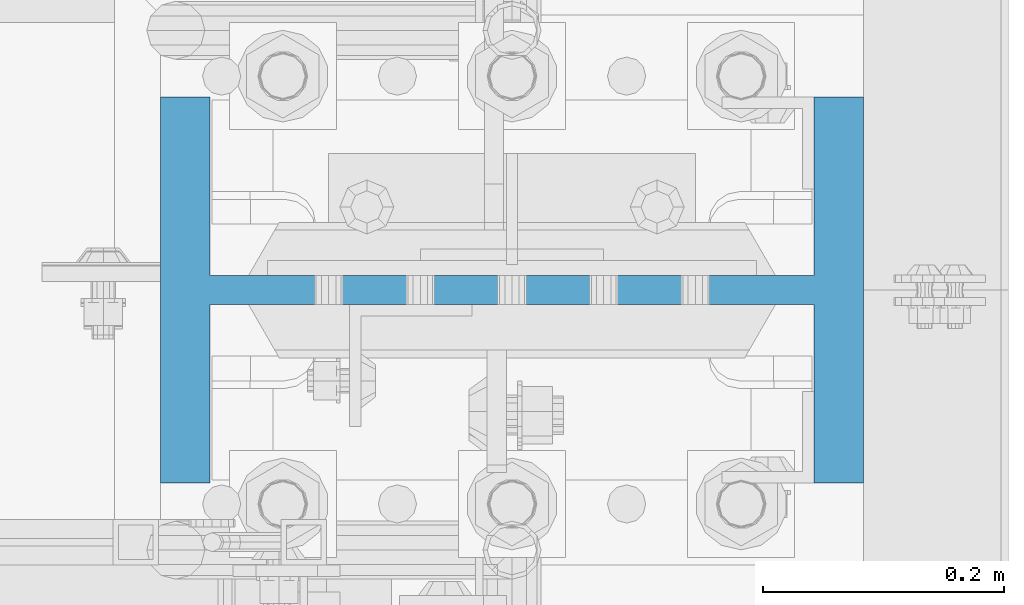
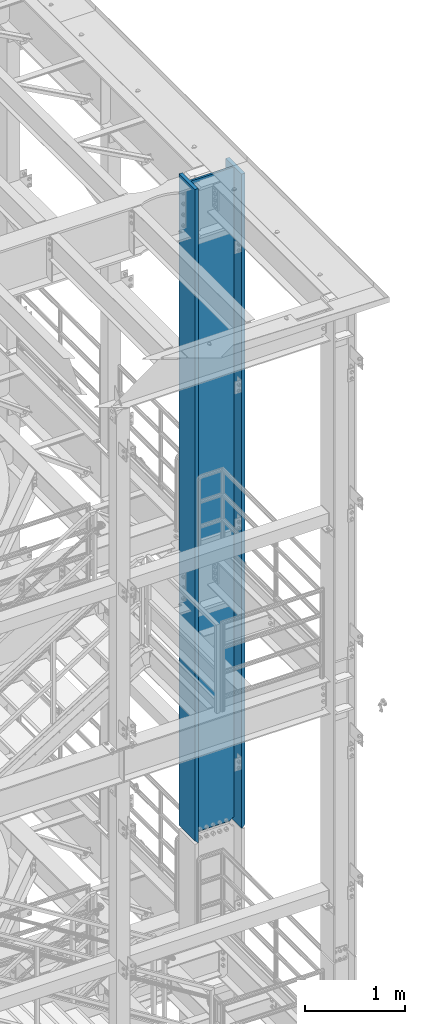
# One storey, part 666 of 1876: 1 column, 1 element without a shape of its own.
"""IFC2X3 building model written with IfcOpenShell, lengths in millimetres."""

from ifc_helpers import new_model, si_unit, frame, origin_with_axes, place, context, subcontext, project, spatial, faceted_brep, material, type_object, element, aggregate, save


model = new_model("IFC2X3")

# Units and contexts
model_context = context("Model", 3, precision=1e-05, world=origin_with_axes())
body_context = subcontext(model_context, "Body", "Model", "MODEL_VIEW")
ifc_project = project(units=[si_unit("LENGTHUNIT", "METRE", prefix="MILLI"), si_unit("AREAUNIT", "SQUARE_METRE"), si_unit("VOLUMEUNIT", "CUBIC_METRE"), si_unit("MASSUNIT", "GRAM", prefix="KILO"), si_unit("TIMEUNIT", "SECOND"), si_unit("PLANEANGLEUNIT", "RADIAN"), si_unit("SOLIDANGLEUNIT", "STERADIAN"), si_unit("THERMODYNAMICTEMPERATUREUNIT", "DEGREE_CELSIUS"), si_unit("LUMINOUSINTENSITYUNIT", "LUMEN")], contexts=[model_context])

# Site, building, storey
site_placement = place(None, origin_with_axes())
site = spatial("IfcSite", under=ifc_project, at=site_placement, CompositionType="ELEMENT")
building_placement = place(site_placement, origin_with_axes())
building = spatial("IfcBuilding", under=site, at=building_placement, Name="Undefined", CompositionType="ELEMENT")
storey_placement = place(building_placement, origin_with_axes())
storey = spatial("IfcBuildingStorey", under=building, at=storey_placement, Name="Undefined", CompositionType="ELEMENT", Elevation=0.0)

# Assembly, column
assembly_placement = place(storey_placement, origin_with_axes())
assembly = element("IfcElementAssembly", 1, at=assembly_placement, inside=storey, Name="COLUMN", AssemblyPlace="NOTDEFINED", PredefinedType="RIGID_FRAME")
ifc_material = material(Name="STEEL/A992")
column_type = type_object("IfcColumnType", Name="W21X201", PredefinedType="NOTDEFINED")
column_placement = place(assembly_placement, frame((7620.0, -4572.0, 14528.8), z_axis=(-1.0, 0.0, 0.0), x_axis=(0.0, 0.0, 1.0)))
column = element("IfcColumn", 2, at=column_placement, type_object=column_type, material=ifc_material, Name="COLUMN", ObjectType="W21X201", context=body_context, shape_type="Brep", body=[
    faceted_brep([(26.9875007629398, -11.9062500000018, 204.691852352942), (25.7903180721823, -10.7090673092443, 203.891920453292), (6.35000000000036, 8.73125076293763, 200.02500076294), (6.35000000000036, 8.73125076293763, -200.02500076294), (25.7903188351211, -10.7090680721831, -203.891920453292), (26.9875007629398, -11.90625, -204.691851843163), (42.2710247077357, -11.90625, -214.903976055204), (42.2710247077357, 11.90625, -214.903976055204), (53.2830803096476, 11.90625, -231.384681927818), (53.2830803096476, -11.90625, -231.384681927818), (8026.4, -160.3375, 292.1), (8026.4, 160.3375, 292.1), (44.4500000000007, 160.3375, 292.1), (44.4500000000007, -160.3375, 292.1), (6.35000000000036, -160.3375, 250.825), (57.1499992370609, -160.3375, 250.825), (8026.4, -160.3375, 250.825), (6.35000000000036, -160.3375, 254.0), (6.35000000000036, -11.90625, 250.825), (6.35000000000036, 160.3375, 254.0), (6.35000000000036, 160.3375, 250.825), (6.35000000000036, 11.90625, 250.825), (6.35000000000036, 8.73125076293763, 250.825), (8026.4, 160.3375, 250.825), (57.1499992370609, 160.3375, 250.825), (57.1499992370609, 11.90625, 250.825), (8026.4, 11.90625, 250.825), (57.1499992370609, -11.90625, 250.825000000001), (53.2830795467089, 11.90625, 231.384681927818), (53.2830795467089, -11.90625, 231.384681927818), (26.9875007629398, -11.90625, 250.825), (8026.4, -11.90625, 250.825), (57.1499999999996, 160.3375, -250.825), (6.35000000000036, 160.3375, -250.825), (6.35000000000036, 11.90625, -250.825), (57.1499999999996, 11.90625, -250.825), (8026.4, 11.90625, -250.825), (8026.4, 160.3375, -250.825), (8026.4, 160.3375, -292.1), (8026.4, -160.3375, -292.1), (44.4500000000007, -160.3375, -292.1), (44.4500000000007, 160.3375, -292.1), (8026.4, -160.3375, -250.825), (57.1499999999996, -160.3375, -250.825), (6.35000000000036, -160.3375, -250.825), (6.35000000000036, -160.3375, -254.000000000001), (6.35000000000036, 160.3375, -254.000000000001), (8026.4, -11.90625, -250.825), (57.1499999999996, -11.90625, -250.825000000001), (26.9875007629398, -11.90625, -250.825), (6.35000000000036, -11.90625, -250.825), (6.35000000000036, 8.73125076293763, -250.825), (25.7903188351211, 11.90625, -203.891920453292), (6.35000000000036, 11.90625, -200.02500076294), (6.35000000000036, 11.90625, 200.02500076294), (25.7903180721823, 11.90625, 203.891920453292), (42.271023944797, 11.90625, 214.903976055204), (42.271023944797, -11.90625, 214.903976055204)], [[[0, 1, 2, 3, 4, 5]], [[6, 7, 8, 9]], [[10, 11, 12, 13]], [[14, 15, 16, 10, 13, 17]], [[18, 14, 17, 19, 20, 21, 22]], [[13, 12, 19, 17]], [[11, 23, 24, 20, 19, 12]], [[25, 21, 20, 24, 23, 26]], [[27, 25, 28, 29]], [[30, 18, 22, 21, 25, 27]], [[15, 14, 18, 30, 27, 31, 16]], [[32, 33, 34, 35, 36, 37]], [[38, 39, 40, 41]], [[39, 42, 43, 44, 45, 40]], [[40, 45, 46, 41]], [[33, 32, 37, 38, 41, 46]], [[36, 26, 23, 11, 10, 16, 31, 47, 42, 39, 38, 37]], [[48, 49, 50, 44, 43, 42, 47]], [[34, 33, 46, 45, 44, 50, 51]], [[49, 48, 35, 34, 51, 50]], [[9, 8, 35, 48]], [[7, 52, 53, 54, 55, 56, 28, 25, 26, 36, 35, 8]], [[29, 28, 56, 57]], [[6, 9, 48, 47, 31, 27, 29, 57, 0, 5]], [[52, 7, 6, 5, 4]], [[53, 52, 4, 3]], [[54, 53, 3, 2]], [[55, 54, 2, 1]], [[57, 56, 55, 1, 0]]]),
])
aggregate(assembly, [column])

save(model, "model.ifc")
